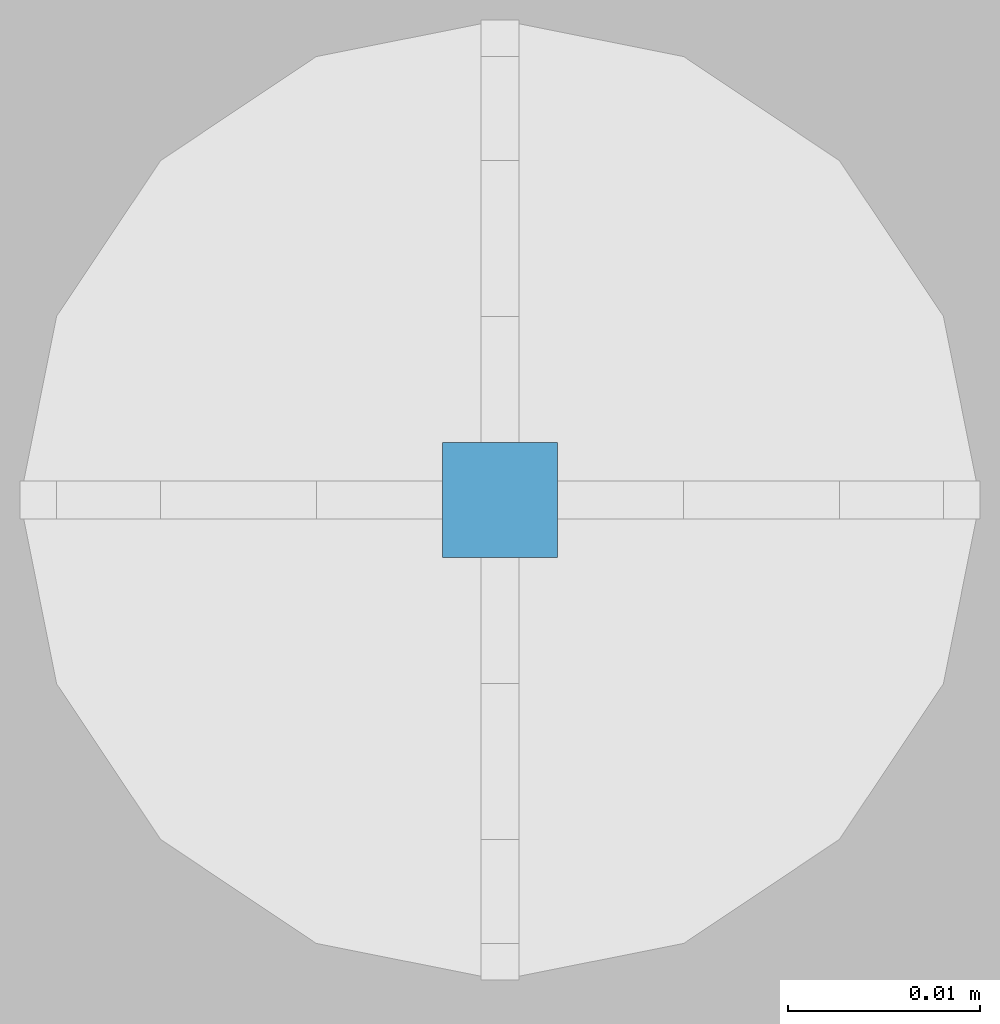
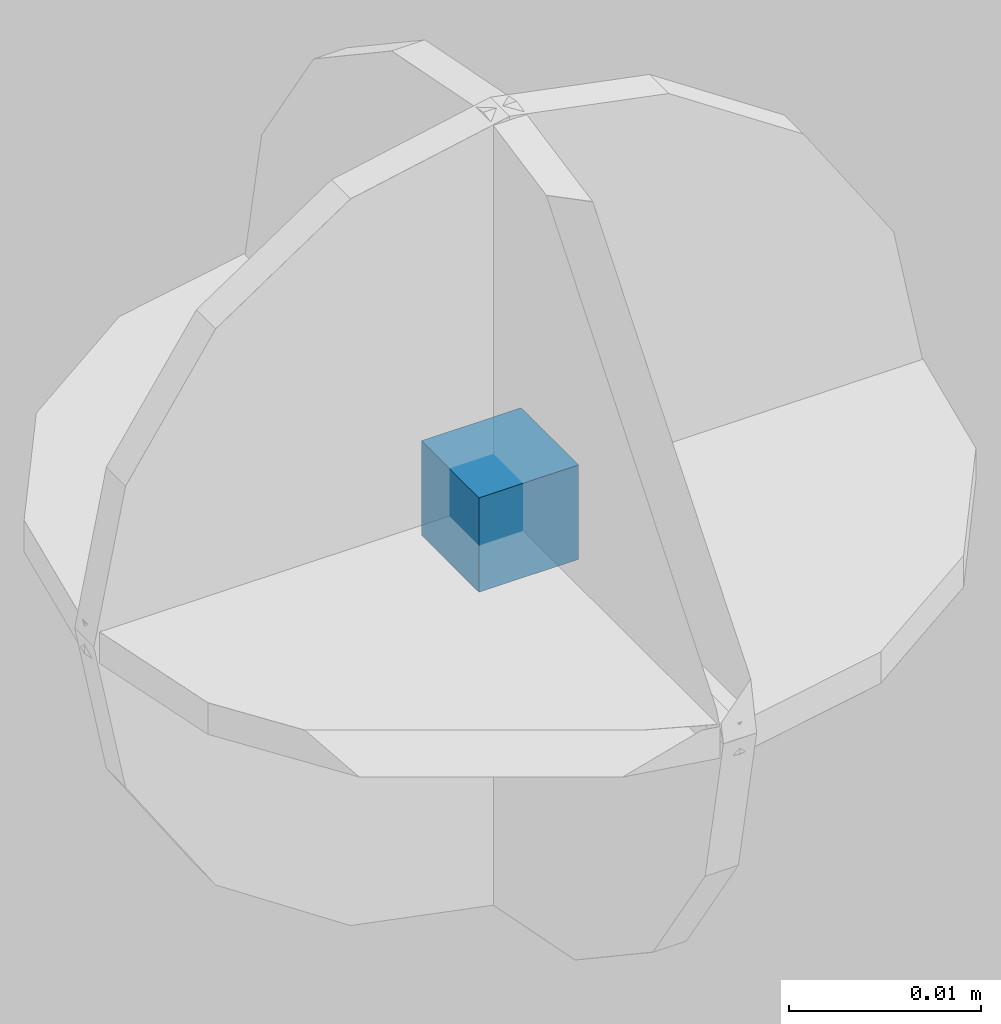
# One storey, part 52 of 264: 3 columns, 4 elements without a shape of their own.
"""IFC2X3 building model written with IfcOpenShell, lengths in millimetres."""

from ifc_helpers import new_model, si_unit, frame, origin_with_axes, place, context, subcontext, project, spatial, faceted_brep, material, type_object, element, aggregate, save


model = new_model("IFC2X3")

# Units and contexts
model_context = context("Model", 3, precision=1e-05, world=origin_with_axes())
body_context = subcontext(model_context, "Body", "Model", "MODEL_VIEW")
ifc_project = project(units=[si_unit("LENGTHUNIT", "METRE", prefix="MILLI"), si_unit("AREAUNIT", "SQUARE_METRE"), si_unit("VOLUMEUNIT", "CUBIC_METRE"), si_unit("MASSUNIT", "GRAM", prefix="KILO"), si_unit("TIMEUNIT", "SECOND"), si_unit("PLANEANGLEUNIT", "RADIAN"), si_unit("SOLIDANGLEUNIT", "STERADIAN"), si_unit("THERMODYNAMICTEMPERATUREUNIT", "DEGREE_CELSIUS"), si_unit("LUMINOUSINTENSITYUNIT", "LUMEN")], contexts=[model_context])

# Site, building, storey
site_placement = place(None, origin_with_axes())
site = spatial("IfcSite", under=ifc_project, at=site_placement, CompositionType="ELEMENT")
building_placement = place(site_placement, origin_with_axes())
building = spatial("IfcBuilding", under=site, at=building_placement, CompositionType="ELEMENT")
storey_placement = place(building_placement, origin_with_axes())
storey = spatial("IfcBuildingStorey", under=building, at=storey_placement, Name="K", CompositionType="ELEMENT", Elevation=0.0)

# Assemblies, columns
assembly_1_placement = place(storey_placement, origin_with_axes())
assembly_1 = element("IfcElementAssembly", 1, at=assembly_1_placement, inside=storey, AssemblyPlace="NOTDEFINED", PredefinedType="REINFORCEMENT_UNIT")
assembly_2_placement = place(assembly_1_placement, origin_with_axes())
assembly_2 = element("IfcElementAssembly", 2, at=assembly_2_placement, Name="Steel Assembly", AssemblyPlace="NOTDEFINED", PredefinedType="RIGID_FRAME")
ifc_material = material(Name="STEEL/Steel_Undefined")
column_type = type_object("IfcColumnType", PredefinedType="NOTDEFINED")
column_1_placement = place(assembly_2_placement, frame((15228.9705646256, 16083.4789537455, 80105.1740603176), z_axis=(1.0, 0.0, 0.0), x_axis=(0.0, 0.0, 1.0)))
column_1 = element("IfcColumn", 3, at=column_1_placement, type_object=column_type, material=ifc_material, Name="PP", context=body_context, shape_type="Brep", body=[
    faceted_brep([(0.0, 3.0, -3.0), (0.0, 2.99999999999636, 3.0), (6.0, 2.99999999999636, 3.0), (6.0, 3.0, -3.0), (0.0, -3.00000000000364, 3.0), (6.0, -3.00000000000364, 3.0), (0.0, -3.0, -3.0), (6.0, -3.0, -3.0)], [[[0, 1, 2, 3]], [[1, 4, 5, 2]], [[4, 6, 7, 5]], [[6, 0, 3, 7]], [[5, 7, 3, 2]], [[6, 4, 1, 0]]]),
])
aggregate(assembly_2, [column_1])
assembly_3_placement = place(assembly_1_placement, origin_with_axes())
assembly_3 = element("IfcElementAssembly", 4, at=assembly_3_placement, Name="Steel Assembly", AssemblyPlace="NOTDEFINED", PredefinedType="RIGID_FRAME")
column_2_placement = place(assembly_3_placement, frame((15228.9705646256, 16083.4789537455, 80105.1623229251), z_axis=(1.0, 0.0, 0.0), x_axis=(0.0, 0.0, 1.0)))
column_2 = element("IfcColumn", 5, at=column_2_placement, type_object=column_type, material=ifc_material, Name="PP", context=body_context, shape_type="Brep", body=[
    faceted_brep([(0.0, 3.0, -3.0), (0.0, 2.99999999999636, 3.0), (6.0, 2.99999999999636, 3.0), (6.0, 3.0, -3.0), (0.0, -3.00000000000364, 3.0), (6.0, -3.00000000000364, 3.0), (0.0, -3.0, -3.0), (6.0, -3.0, -3.0)], [[[0, 1, 2, 3]], [[1, 4, 5, 2]], [[4, 6, 7, 5]], [[6, 0, 3, 7]], [[5, 7, 3, 2]], [[6, 4, 1, 0]]]),
])
aggregate(assembly_3, [column_2])
assembly_4_placement = place(assembly_1_placement, origin_with_axes())
assembly_4 = element("IfcElementAssembly", 6, at=assembly_4_placement, Name="Steel Assembly", AssemblyPlace="NOTDEFINED", PredefinedType="RIGID_FRAME")
aggregate(assembly_1, [assembly_2, assembly_3, assembly_4])
column_3_placement = place(assembly_4_placement, frame((15228.9705646256, 16083.4789537455, 80105.1623229251), z_axis=(1.0, 0.0, 0.0), x_axis=(0.0, 0.0, 1.0)))
column_3 = element("IfcColumn", 7, at=column_3_placement, type_object=column_type, material=ifc_material, Name="PP", context=body_context, shape_type="Brep", body=[
    faceted_brep([(0.0, 3.0, -3.0), (0.0, 2.99999999999636, 3.0), (6.0, 2.99999999999636, 3.0), (6.0, 3.0, -3.0), (0.0, -3.00000000000364, 3.0), (6.0, -3.00000000000364, 3.0), (0.0, -3.0, -3.0), (6.0, -3.0, -3.0)], [[[0, 1, 2, 3]], [[1, 4, 5, 2]], [[4, 6, 7, 5]], [[6, 0, 3, 7]], [[5, 7, 3, 2]], [[6, 4, 1, 0]]]),
])
aggregate(assembly_4, [column_3])

save(model, "model.ifc")
